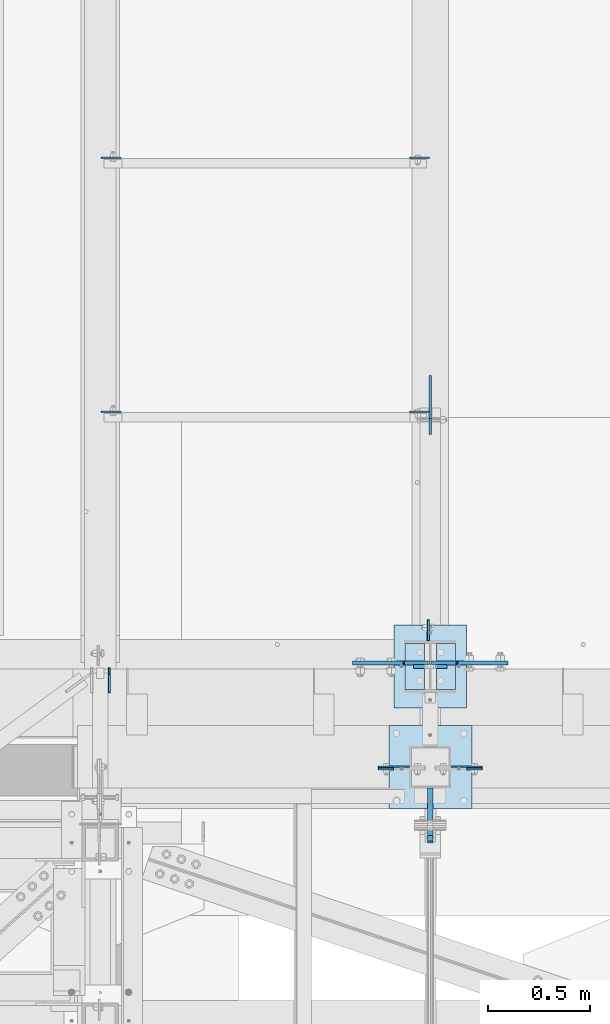
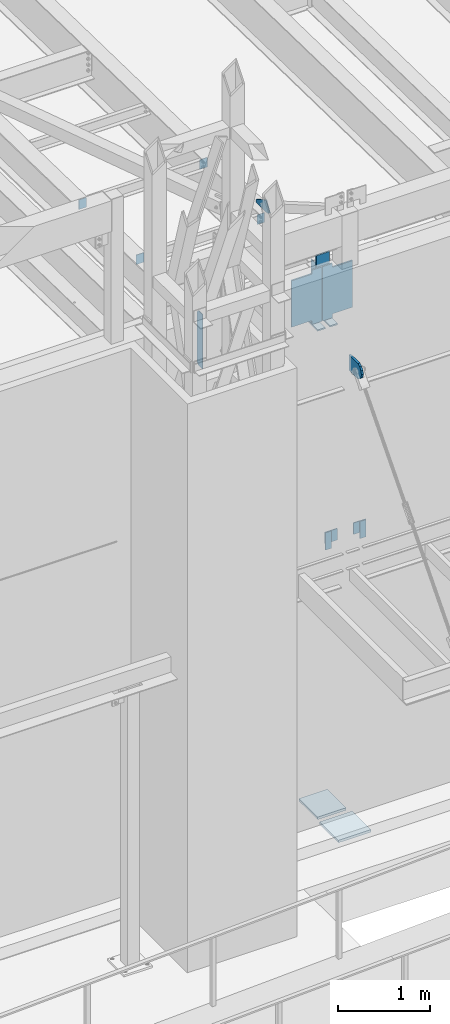
# One storey, part 1453 of 1763: 19 plates, 7 elements without a shape of their own.
"""IFC2X3 building model written with IfcOpenShell, lengths in millimetres."""

import ifcopenshell
import ifcopenshell.guid

model = None  # the IFC model being written
_history = None  # IfcOwnerHistory: only IFC2X3 demands one
_inside = {}  # id of a spatial element -> (the spatial element, [elements in it])
_under = {}  # id of a project, library or spatial element -> (it, [spatial elements below it])
_declared = {}  # id of a project -> (the project, [libraries it declares])
_typed = {}  # id of a type object -> (the type object, [elements of that type])
_made_of = {}  # id of a material, layer set ... -> (it, [elements and type objects made of it])


def new_model(schema):
    """Start an empty IFC model of exactly this schema.

    Asked for "IFC4X3", IfcOpenShell would pick the latest addendum, in which some entities
    have other attributes; the version numbers below select the first issue.
    IFC2X3 requires an IfcOwnerHistory on every rooted entity: one is made here for all.
    """
    global model, _history
    if schema == "IFC4X3":
        model = ifcopenshell.file(schema_version=(4, 3, 0, 0))
    else:
        model = ifcopenshell.file(schema=schema)
    _inside.clear()
    _under.clear()
    _declared.clear()
    _typed.clear()
    _made_of.clear()
    _history = None
    if model.schema == "IFC2X3":
        org = make("IfcOrganization", Name="unknown")
        user = make(
            "IfcPersonAndOrganization",
            ThePerson=make("IfcPerson", FamilyName="unknown"),
            TheOrganization=org,
        )
        app = make(
            "IfcApplication",
            ApplicationDeveloper=org,
            Version="unknown",
            ApplicationFullName="unknown",
            ApplicationIdentifier="unknown",
        )
        _history = make(
            "IfcOwnerHistory",
            OwningUser=user,
            OwningApplication=app,
            ChangeAction="ADDED",
            CreationDate=0,
        )
    return model


def make(cls, **values):
    """One entity of the class cls with the attributes given. An attribute that is None is left unset."""
    return model.create_entity(
        cls, **{name: value for name, value in values.items() if value is not None}
    )


def rooted(cls, **values):
    """An entity with a GlobalId (a new one), such as an element, a storey or a relation."""
    return make(cls, GlobalId=ifcopenshell.guid.new(), OwnerHistory=_history, **values)


def si_unit(unit_type, name, prefix=None):
    """IfcSIUnit, for example si_unit("LENGTHUNIT", "METRE", prefix="MILLI")."""
    return make("IfcSIUnit", UnitType=unit_type, Prefix=prefix, Name=name)


def assignment(units):
    """IfcUnitAssignment: the units of a project."""
    return None if units is None else make("IfcUnitAssignment", Units=units)


def point(xyz):
    """IfcCartesianPoint."""
    return None if xyz is None else make("IfcCartesianPoint", Coordinates=xyz)


def direction(xyz):
    """IfcDirection."""
    return None if xyz is None else make("IfcDirection", DirectionRatios=xyz)


def frame(location, z_axis=None, x_axis=None):
    """IfcAxis2Placement3D, a coordinate frame: its origin and axes. An axis left out is left unset."""
    return make(
        "IfcAxis2Placement3D",
        Location=point(location),
        Axis=direction(z_axis),
        RefDirection=direction(x_axis),
    )


def origin_with_axes():
    """The frame at (0, 0, 0) with the z axis (0, 0, 1) and the x axis (1, 0, 0) written out."""
    return frame((0.0, 0.0, 0.0), z_axis=(0.0, 0.0, 1.0), x_axis=(1.0, 0.0, 0.0))


def place(relative_to, where):
    """IfcLocalPlacement: puts the frame where relative to a parent placement (None: the world)."""
    return make(
        "IfcLocalPlacement", PlacementRelTo=relative_to, RelativePlacement=where
    )


def context(
    kind, dimensions, precision=None, world=None, true_north=None, identifier=None
):
    """IfcGeometricRepresentationContext, for example the 3D "Model" context."""
    return make(
        "IfcGeometricRepresentationContext",
        ContextIdentifier=identifier,
        ContextType=kind,
        CoordinateSpaceDimension=dimensions,
        Precision=precision,
        WorldCoordinateSystem=world,
        TrueNorth=true_north,
    )


def subcontext(parent, identifier, kind, view, scale=None):
    """IfcGeometricRepresentationSubContext, for example "Body" below "Model"."""
    return make(
        "IfcGeometricRepresentationSubContext",
        ContextIdentifier=identifier,
        ContextType=kind,
        ParentContext=parent,
        TargetScale=scale,
        TargetView=view,
    )


def project(units=None, contexts=None):
    """IfcProject with its units and contexts."""
    return rooted(
        "IfcProject",
        Name="project",
        RepresentationContexts=contexts,
        UnitsInContext=assignment(units),
    )


def spatial(cls, under=None, at=None, **own):
    """A site, building, storey or space (cls), placed at a placement, below another one or the project."""
    s = rooted(cls, ObjectPlacement=at, **own)
    if under is not None:
        _under.setdefault(under.id(), (under, []))[1].append(s)
    return s


def faces_of(points, faces, orient=None, outer=None):
    """IfcFace entities. A face is a list of loops; a loop is a list of indices into points, from 0.

    orient and outer hold one flag for each loop. By default every Orientation is true, the
    first loop of a face is its IfcFaceOuterBound and the others are IfcFaceBound.
    """
    made = []
    for i, loops in enumerate(faces):
        bounds = []
        for j, loop in enumerate(loops):
            is_outer = j == 0 if outer is None else outer[i][j]
            bounds.append(
                make(
                    "IfcFaceOuterBound" if is_outer else "IfcFaceBound",
                    Bound=make("IfcPolyLoop", Polygon=[points[k] for k in loop]),
                    Orientation=True if orient is None else orient[i][j],
                )
            )
        made.append(make("IfcFace", Bounds=bounds))
    return made


def faceted_brep(points, faces, orient=None, outer=None, voids=None):
    """IfcFacetedBrep: a solid bounded by flat faces; with voids (closed shells), ...WithVoids."""
    shared = [point(p) for p in points]
    hull = make("IfcClosedShell", CfsFaces=faces_of(shared, faces, orient, outer))
    if voids is None:
        return make("IfcFacetedBrep", Outer=hull)
    return make(
        "IfcFacetedBrepWithVoids",
        Outer=hull,
        Voids=[
            make(cls, CfsFaces=faces_of(shared, fs, o, b)) for cls, fs, o, b in voids
        ],
    )


def shape(context_of_items, identifier, shape_type, items):
    """IfcShapeRepresentation: the items that make up one representation, for example the "Body"."""
    return make(
        "IfcShapeRepresentation",
        ContextOfItems=context_of_items,
        RepresentationIdentifier=identifier,
        RepresentationType=shape_type,
        Items=items,
    )


def material(Name=None, Category=None):
    """IfcMaterial."""
    return make("IfcMaterial", Name=Name, Category=Category)


def made_of(thing, what):
    """Note that an element or type object is made of a material, layer set ...; save() writes the relation."""
    if what is not None:
        _made_of.setdefault(what.id(), (what, []))[1].append(thing)
    return thing


def type_object(cls, material=None, **own):
    """A type object (cls), such as IfcWallType, which elements share."""
    return made_of(rooted(cls, **own), material)


def element(
    cls,
    number,
    at=None,
    inside=None,
    cuts=None,
    type_object=None,
    material=None,
    context=None,
    identifier="Body",
    shape_type=None,
    held_by="IfcProductDefinitionShape",
    body=None,
    shapes=None,
    **own,
):
    """One element of the class cls, such as IfcWall. Its Tag is "e" and its number.

    at: its placement. inside: the storey or other place that contains it. cuts: it is an
    opening in that element (IfcRelVoidsElement). A single representation is given by context,
    identifier, shape_type and body (its items); several are given by shapes. held_by: the class
    of the entity that holds the representations. save() writes the other relations.
    """
    e = rooted(cls, Tag="e%d" % number, ObjectPlacement=at, **own)
    if body is not None:
        shapes = [shape(context, identifier, shape_type, body)]
    if shapes is not None:
        e.Representation = make(held_by, Representations=shapes)
    if inside is not None:
        _inside.setdefault(inside.id(), (inside, []))[1].append(e)
    if cuts is not None:
        rooted(
            "IfcRelVoidsElement", RelatingBuildingElement=cuts, RelatedOpeningElement=e
        )
    if type_object is not None:
        _typed.setdefault(type_object.id(), (type_object, []))[1].append(e)
    return made_of(e, material)


def aggregate(whole, parts):
    """IfcRelAggregates: a whole, such as a stair, and the parts it consists of."""
    return rooted("IfcRelAggregates", RelatingObject=whole, RelatedObjects=parts)


def save(model, path):
    """Write the relations noted so far, then the file.

    IfcRelAggregates (storeys below a building ...), IfcRelContainedInSpatialStructure (elements
    in a storey), IfcRelDefinesByType, IfcRelAssociatesMaterial and IfcRelDeclares: one each for
    every whole, place, type object, material and project.
    """
    for whole, parts in _under.values():
        aggregate(whole, parts)
    for where, things in _inside.values():
        rooted(
            "IfcRelContainedInSpatialStructure",
            RelatedElements=things,
            RelatingStructure=where,
        )
    for kind, things in _typed.values():
        rooted("IfcRelDefinesByType", RelatedObjects=things, RelatingType=kind)
    for what, things in _made_of.values():
        rooted("IfcRelAssociatesMaterial", RelatedObjects=things, RelatingMaterial=what)
    for by, libraries in _declared.values():
        rooted("IfcRelDeclares", RelatingContext=by, RelatedDefinitions=libraries)
    model.write(path)


model = new_model("IFC2X3")

# Units and contexts
model_context = context("Model", 3, precision=1e-05, world=origin_with_axes())
body_context = subcontext(model_context, "Body", "Model", "MODEL_VIEW")
ifc_project = project(units=[si_unit("LENGTHUNIT", "METRE", prefix="MILLI"), si_unit("AREAUNIT", "SQUARE_METRE"), si_unit("VOLUMEUNIT", "CUBIC_METRE"), si_unit("MASSUNIT", "GRAM", prefix="KILO"), si_unit("TIMEUNIT", "SECOND"), si_unit("PLANEANGLEUNIT", "RADIAN"), si_unit("SOLIDANGLEUNIT", "STERADIAN"), si_unit("THERMODYNAMICTEMPERATUREUNIT", "DEGREE_CELSIUS"), si_unit("LUMINOUSINTENSITYUNIT", "LUMEN")], contexts=[model_context])

# Site, building, storey
site_placement = place(None, origin_with_axes())
site = spatial("IfcSite", under=ifc_project, at=site_placement, CompositionType="ELEMENT")
building_placement = place(site_placement, origin_with_axes())
building = spatial("IfcBuilding", under=site, at=building_placement, Name="Undefined", CompositionType="ELEMENT")
storey_placement = place(building_placement, origin_with_axes())
storey = spatial("IfcBuildingStorey", under=building, at=storey_placement, Name="Undefined", CompositionType="ELEMENT", Elevation=0.0)

# Assembly, plate
assembly_1_placement = place(storey_placement, origin_with_axes())
assembly_1 = element("IfcElementAssembly", 1, at=assembly_1_placement, inside=storey, Name="BEAM", AssemblyPlace="NOTDEFINED", PredefinedType="RIGID_FRAME")
ifc_material_1 = material(Name="STEEL/A36")
plate_type_1 = type_object("IfcPlateType", PredefinedType="NOTDEFINED")
plate_1_placement = place(assembly_1_placement, frame((-61772.2270217928, -14217.6526375877, 8839.2), z_axis=(0.0, 0.0, 1.0), x_axis=(-1.0, 0.0, 0.0)))
plate_1 = element("IfcPlate", 2, at=plate_1_placement, type_object=plate_type_1, material=ifc_material_1, Name="PLATE", context=body_context, shape_type="Brep", body=[
    faceted_brep([(0.0, -4.76249999999982, 0.0), (-2.83762346953154e-10, -4.7624999996915, 228.600006103516), (-2.83762346953154e-10, 4.76250000028813, 228.600006103517), (0.0, 4.76249999999982, 0.0), (76.1999969480166, -4.76249999961874, 228.600006103516), (76.1999969480166, 4.76250000036089, 228.600006103517), (76.1999969482931, -4.76249999991705, 0.0), (76.1999969482931, 4.76250000006257, 1.81898940354586e-12)], [[[0, 1, 2, 3]], [[1, 4, 5, 2]], [[4, 6, 7, 5]], [[6, 0, 3, 7]], [[5, 7, 3, 2]], [[6, 4, 1, 0]]]),
])
aggregate(assembly_1, [plate_1])

assembly_2_placement = place(storey_placement, origin_with_axes())
assembly_2 = element("IfcElementAssembly", 3, at=assembly_2_placement, inside=storey, Name="BEAM", AssemblyPlace="NOTDEFINED", PredefinedType="RIGID_FRAME")
plate_2_placement = place(assembly_2_placement, frame((-61416.6269978255, -14217.6526358086, 8839.2), z_axis=(0.0, 0.0, 1.0), x_axis=(1.0, 0.0, 0.0)))
plate_2 = element("IfcPlate", 4, at=plate_2_placement, type_object=plate_type_1, material=ifc_material_1, Name="PLATE", context=body_context, shape_type="Brep", body=[
    faceted_brep([(0.0, -4.76249999999982, 0.0), (-2.83762346953154e-10, -4.7624999996915, 228.600006103516), (-2.83762346953154e-10, 4.76250000028813, 228.600006103517), (0.0, 4.76249999999982, 0.0), (76.1999969480166, -4.76249999961874, 228.600006103516), (76.1999969480166, 4.76250000036089, 228.600006103517), (76.1999969482931, -4.76249999991705, 0.0), (76.1999969482931, 4.76250000006257, 1.81898940354586e-12)], [[[0, 1, 2, 3]], [[1, 4, 5, 2]], [[4, 6, 7, 5]], [[6, 0, 3, 7]], [[5, 7, 3, 2]], [[6, 4, 1, 0]]]),
])
aggregate(assembly_2, [plate_2])

assembly_3_placement = place(storey_placement, origin_with_axes())
assembly_3 = element("IfcElementAssembly", 5, at=assembly_3_placement, inside=storey, Name="BEAM", AssemblyPlace="NOTDEFINED", PredefinedType="RIGID_FRAME")
plate_type_2 = type_object("IfcPlateType", PredefinedType="NOTDEFINED")
plate_3_placement = place(assembly_3_placement, frame((-63166.0535957005, -13843.7935686174, 11466.5125), z_axis=(0.0, 0.0, 1.0), x_axis=(0.0, 1.0, 0.0)))
plate_3 = element("IfcPlate", 6, at=plate_3_placement, type_object=plate_type_2, material=ifc_material_1, Name="PLATE", context=body_context, shape_type="Brep", body=[
    faceted_brep([(0.0, -4.76249999999982, 0.0), (0.0, -4.76249999999709, 717.549987792969), (0.0, 4.76249999999709, 717.549987792969), (0.0, 4.76249999999982, 0.0), (88.9000015258789, -4.76249999999709, 717.549987792969), (88.9000015258789, 4.76249999999709, 717.549987792969), (120.650001525879, -4.76249999999709, 685.799987792969), (120.650001525879, 4.76249999999709, 685.799987792969), (120.650001525879, -4.76249999999709, 31.75), (120.650001525879, 4.76249999999709, 31.75), (88.9000015258789, -4.76249999999709, 0.0), (88.9000015258789, 4.76249999999709, 0.0)], [[[0, 1, 2, 3]], [[1, 4, 5, 2]], [[4, 6, 7, 5]], [[6, 8, 9, 7]], [[8, 10, 11, 9]], [[10, 0, 3, 11]], [[5, 7, 9, 11, 3, 2]], [[10, 8, 6, 4, 1, 0]]]),
])
aggregate(assembly_3, [plate_3])

# Assembly, plates
assembly_4_placement = place(storey_placement, origin_with_axes())
assembly_4 = element("IfcElementAssembly", 7, at=assembly_4_placement, inside=storey, Name="COLUMN", AssemblyPlace="NOTDEFINED", PredefinedType="RIGID_FRAME")
plate_type_3 = type_object("IfcPlateType", PredefinedType="NOTDEFINED")
plate_4_placement = place(assembly_4_placement, frame((-61848.4270187887, -14208.1276390874, 9067.80000610352), z_axis=(0.0, 0.0, -1.0), x_axis=(1.0, 0.0, 0.0)))
plate_4 = element("IfcPlate", 8, at=plate_4_placement, type_object=plate_type_3, material=ifc_material_1, Name="PLATE", context=body_context, shape_type="Brep", body=[
    faceted_brep([(0.0, -4.76249999999982, 0.0), (-3.05175672110636e-06, -4.7625000002663, 152.399993896484), (-3.05175490211695e-06, 4.76249999972788, 152.399993896484), (0.0, 4.76249999999982, 0.0), (152.400009155272, -4.76249999975698, 152.399993896484), (152.400009155273, 4.76250000024447, 152.399993896484), (152.400009155272, -4.76249999948777, 5.45696821063757e-12), (152.400009155273, 4.76250000051368, 3.63797880709171e-12)], [[[0, 1, 2, 3]], [[1, 4, 5, 2]], [[4, 6, 7, 5]], [[6, 0, 3, 7]], [[5, 7, 3, 2]], [[6, 4, 1, 0]]]),
])
plate_5_placement = place(assembly_4_placement, frame((-61340.4270009248, -14208.1276365458, 9067.80000610352), z_axis=(0.0, 0.0, -1.0), x_axis=(-1.0, 0.0, 0.0)))
plate_5 = element("IfcPlate", 9, at=plate_5_placement, type_object=plate_type_3, material=ifc_material_1, Name="PLATE", context=body_context, shape_type="Brep", body=[
    faceted_brep([(0.0, -4.76249999999982, 0.0), (-3.05175672110636e-06, -4.7625000002663, 152.399993896484), (-3.05175490211695e-06, 4.76249999972788, 152.399993896484), (0.0, 4.76249999999982, 0.0), (152.400009155272, -4.76249999975698, 152.399993896484), (152.400009155273, 4.76250000024447, 152.399993896484), (152.400009155272, -4.76249999948777, 5.45696821063757e-12), (152.400009155273, 4.76250000051368, 3.63797880709171e-12)], [[[0, 1, 2, 3]], [[1, 4, 5, 2]], [[4, 6, 7, 5]], [[6, 0, 3, 7]], [[5, 7, 3, 2]], [[6, 4, 1, 0]]]),
])

assembly_5_placement = place(storey_placement, origin_with_axes())
assembly_5 = element("IfcElementAssembly", 10, at=assembly_5_placement, inside=storey, Name="BEAM", AssemblyPlace="NOTDEFINED", PredefinedType="RIGID_FRAME")
plate_type_4 = type_object("IfcPlateType", PredefinedType="NOTDEFINED")
plate_6_placement = place(assembly_5_placement, frame((-63205.5045725783, -12468.6187192313, 12153.2886368763), z_axis=(1.0, 0.0, 0.0), x_axis=(0.0, 0.0, -1.0)))
plate_6 = element("IfcPlate", 11, at=plate_6_placement, type_object=plate_type_4, material=ifc_material_1, Name="PLATE", context=body_context, shape_type="Brep", body=[
    faceted_brep([(1.81898940354586e-12, -3.17500000000291, 0.0), (0.0, -3.17499999999927, 95.25), (0.0, 3.17499999999927, 95.25), (-1.81898940354586e-12, 3.17499999997381, 0.0), (127.0, -3.17499999999927, 95.25), (127.0, 3.17499999999927, 95.25), (127.0, -3.17499999999927, 0.0), (127.0, 3.17499999999927, 0.0)], [[[0, 1, 2, 3]], [[1, 4, 5, 2]], [[4, 6, 7, 5]], [[6, 0, 3, 7]], [[5, 7, 3, 2]], [[6, 4, 1, 0]]]),
])
plate_7_placement = place(assembly_5_placement, frame((-63205.5045725783, -11224.4126198456, 12127.2773623981), z_axis=(1.0, 0.0, 0.0), x_axis=(0.0, 0.0, -1.0)))
plate_7 = element("IfcPlate", 12, at=plate_7_placement, type_object=plate_type_4, material=ifc_material_1, Name="PLATE", context=body_context, shape_type="Brep", body=[
    faceted_brep([(1.81898940354586e-12, -3.17500000000291, 0.0), (0.0, -3.17499999999927, 95.25), (0.0, 3.17499999999927, 95.25), (-1.81898940354586e-12, 3.17499999997381, 0.0), (127.0, -3.17499999999927, 95.25), (127.0, 3.17499999999927, 95.25), (127.0, -3.17499999999927, 0.0), (127.0, 3.17499999999927, 0.0)], [[[0, 1, 2, 3]], [[1, 4, 5, 2]], [[4, 6, 7, 5]], [[6, 0, 3, 7]], [[5, 7, 3, 2]], [[6, 4, 1, 0]]]),
])
aggregate(assembly_5, [plate_6, plate_7])

assembly_6_placement = place(storey_placement, origin_with_axes())
assembly_6 = element("IfcElementAssembly", 13, at=assembly_6_placement, inside=storey, Name="BEAM", AssemblyPlace="NOTDEFINED", PredefinedType="RIGID_FRAME")
plate_8_placement = place(assembly_6_placement, frame((-61599.1997736983, -12468.6187192313, 12153.2886368765), z_axis=(-1.0, 0.0, 0.0), x_axis=(0.0, 0.0, -1.0)))
plate_8 = element("IfcPlate", 14, at=plate_8_placement, type_object=plate_type_4, material=ifc_material_1, Name="PLATE", context=body_context, shape_type="Brep", body=[
    faceted_brep([(1.81898940354586e-12, -3.17500000000291, 0.0), (0.0, -3.17499999999927, 95.25), (0.0, 3.17499999999927, 95.25), (-1.81898940354586e-12, 3.17499999997381, 0.0), (127.0, -3.17499999999927, 95.25), (127.0, 3.17499999999927, 95.25), (127.0, -3.17499999999927, 0.0), (127.0, 3.17499999999927, 0.0)], [[[0, 1, 2, 3]], [[1, 4, 5, 2]], [[4, 6, 7, 5]], [[6, 0, 3, 7]], [[5, 7, 3, 2]], [[6, 4, 1, 0]]]),
])
plate_9_placement = place(assembly_6_placement, frame((-61599.1997736983, -11224.4126198457, 12127.2773623985), z_axis=(-1.0, 0.0, 0.0), x_axis=(0.0, 0.0, -1.0)))
plate_9 = element("IfcPlate", 15, at=plate_9_placement, type_object=plate_type_4, material=ifc_material_1, Name="PLATE", context=body_context, shape_type="Brep", body=[
    faceted_brep([(1.81898940354586e-12, -3.17500000000291, 0.0), (0.0, -3.17499999999927, 95.25), (0.0, 3.17499999999927, 95.25), (-1.81898940354586e-12, 3.17499999997381, 0.0), (127.0, -3.17499999999927, 95.25), (127.0, 3.17499999999927, 95.25), (127.0, -3.17499999999927, 0.0), (127.0, 3.17499999999927, 0.0)], [[[0, 1, 2, 3]], [[1, 4, 5, 2]], [[4, 6, 7, 5]], [[6, 0, 3, 7]], [[5, 7, 3, 2]], [[6, 4, 1, 0]]]),
])

# Plate
plate_type_5 = type_object("IfcPlateType", PredefinedType="NOTDEFINED")
plate_10_placement = place(assembly_4_placement, frame((-61594.4270083209, -14503.4026217954, 11188.7000003081), z_axis=(0.0, 0.0, 1.0), x_axis=(0.0, 1.0, 0.0)))
plate_10 = element("IfcPlate", 16, at=plate_10_placement, type_object=plate_type_5, material=ifc_material_1, Name="PLATE", context=body_context, shape_type="Brep", body=[
    faceted_brep([(0.0, -12.6999999999971, -1.81898940354586e-12), (-39.5764506670585, -12.6999999999971, 21.5331529121049), (-39.5764506670585, 12.6999999999971, 21.5331529121049), (0.0, 12.6999999999971, -1.81898940354586e-12), (-66.6095773920388, -12.6999999999971, 57.5773227764421), (-66.6095773920388, 12.6999999999971, 57.5773227764421), (-76.199996948335, -12.6999999999971, 101.599998461508), (-76.199996948335, 12.6999999999971, 101.599998461508), (-66.6095774066125, -12.6999999999971, 145.622674149748), (-66.6095774066125, 12.6999999999971, 145.622674149748), (-39.5764506935648, -12.6999999999971, 181.666844023039), (-39.5764506935648, 12.6999999999971, 181.666844023039), (-3.36349330609664e-08, -12.6999999999971, 203.199996948242), (-3.36349330609664e-08, 12.6999999999971, 203.199996948242), (193.675003051578, -12.6999999999971, 203.199996948413), (193.675003051578, 12.6999999999971, 203.199996948413), (193.675003051758, -12.6999999999971, 3.09228198602796e-10), (193.675003051758, 12.6999999999971, 3.09228198602796e-10)], [[[0, 1, 2, 3]], [[1, 4, 5, 2]], [[4, 6, 7, 5]], [[6, 8, 9, 7]], [[8, 10, 11, 9]], [[10, 12, 13, 11]], [[12, 14, 15, 13]], [[14, 16, 17, 15]], [[16, 0, 3, 17]], [[5, 7, 9, 11, 13, 15, 17, 3, 2]], [[16, 14, 12, 10, 8, 6, 4, 1, 0]]]),
])

# Assembly, plate
assembly_7_placement = place(storey_placement, origin_with_axes())
assembly_7 = element("IfcElementAssembly", 17, at=assembly_7_placement, inside=storey, Name="COLUMN", AssemblyPlace="NOTDEFINED", PredefinedType="RIGID_FRAME")
ifc_material_2 = material(Name="STEEL/A572-50")
plate_type_6 = type_object("IfcPlateType", PredefinedType="NOTDEFINED")
plate_11_placement = place(assembly_7_placement, frame((-61511.8872721725, -13715.9998186171, 12369.7999938965), z_axis=(0.0, 0.0, -1.0), x_axis=(-1.0, 0.0, 0.0)))
plate_11 = element("IfcPlate", 18, at=plate_11_placement, type_object=plate_type_6, material=ifc_material_2, Name="PLATE", context=body_context, shape_type="Brep", body=[
    faceted_brep([(7.27595761418343e-12, 9.52500000000146, 155.574990844727), (-1.45519152283669e-11, 7.27595761418343e-12, 165.099990844727), (165.099990844727, 0.0, 165.099990844727), (165.099990844727, 9.52500000000146, 155.574990844727), (-3.63797880709171e-11, -9.5249999999869, 155.574990844727), (165.099990844727, -9.52500000000146, 155.574990844727), (0.0, 9.52500000000146, 0.0), (0.0, -9.52500000000146, 0.0), (165.099990844727, -9.52500000000146, 0.0), (165.099990844727, 9.52500000000146, 0.0)], [[[0, 1, 2, 3]], [[1, 4, 5, 2]], [[6, 7, 4, 1, 0]], [[5, 8, 9, 3, 2]], [[8, 7, 6, 9]], [[9, 6, 0, 3]], [[7, 8, 5, 4]]]),
])

# Plate
plate_type_7 = type_object("IfcPlateType", PredefinedType="NOTDEFINED")
plate_12_placement = place(assembly_6_placement, frame((-61594.4377751502, -12289.5645131378, 12174.8790507221), z_axis=(0.0, -1.0, 0.0), x_axis=(0.0, 0.0, 1.0)))
plate_12 = element("IfcPlate", 19, at=plate_12_placement, type_object=plate_type_7, material=ifc_material_1, Name="PLATE", context=body_context, shape_type="Brep", body=[
    faceted_brep([(0.0, -6.34999999999491, 1.45519152283669e-11), (3.45059657096863, -6.34999999999854, 165.063949584961), (3.45059657096863, 6.34999999999854, 165.063949584961), (0.0, 6.34999999999491, -2.91038304567337e-11), (5.01950931549072, -6.34999999999854, 240.10026550293), (5.01950931549072, 6.34999999999854, 240.10026550293), (33.3607749938965, -6.34999999999854, 288.962707519531), (33.3607749938965, 6.34999999999854, 288.962707519531), (165.188125610352, -6.34999999999854, 212.500045776367), (165.188125610352, 6.34999999999854, 212.500045776367), (41.9335784912109, -6.34999999999854, 0.0), (41.9335784912109, 6.34999999999854, 0.0)], [[[0, 1, 2, 3]], [[1, 4, 5, 2]], [[4, 6, 7, 5]], [[6, 8, 9, 7]], [[8, 10, 11, 9]], [[10, 0, 3, 11]], [[5, 7, 9, 11, 3, 2]], [[10, 8, 6, 4, 1, 0]]]),
])

aggregate(assembly_6, [plate_8, plate_9, plate_12])

plate_type_8 = type_object("IfcPlateType", PredefinedType="NOTDEFINED")
plate_13_placement = place(assembly_7_placement, frame((-61603.9622736983, -13588.9999999999, 12162.6007753759), z_axis=(0.0, 1.0, 0.0), x_axis=(0.0, 0.0, -1.0)))
plate_13 = element("IfcPlate", 20, at=plate_13_placement, type_object=plate_type_8, material=ifc_material_1, Name="PLATE", context=body_context, shape_type="Brep", body=[
    faceted_brep([(0.0, -4.76249999999982, 0.0), (1.45519152283669e-11, -4.76250000000448, 101.60001373291), (0.0, 4.76250000000243, 101.60001373291), (0.0, 4.76249999999982, 0.0), (533.400024414062, -4.76249999999709, 101.599998474121), (533.400024414062, 4.76249999999709, 101.599998474121), (533.400024414062, -4.76250000000073, 0.0), (533.400024414062, 4.76250000000073, 0.0)], [[[0, 1, 2, 3]], [[1, 4, 5, 2]], [[4, 6, 7, 5]], [[6, 0, 3, 7]], [[5, 7, 3, 2]], [[6, 4, 1, 0]]]),
])

plate_type_9 = type_object("IfcPlateType", PredefinedType="NOTDEFINED")
plate_14_placement = place(assembly_7_placement, frame((-61598.4060236983, -13699.3310686171, 12184.0625), z_axis=(-1.0, 0.0, 0.0), x_axis=(0.0, 0.0, -1.0)))
plate_14 = element("IfcPlate", 21, at=plate_14_placement, type_object=plate_type_9, material=ifc_material_2, Name="PLATE", context=body_context, shape_type="Brep", body=[
    faceted_brep([(38.0999994277954, -9.52499999999964, 123.03125), (38.0999994277954, 9.52499999999964, 123.03125), (0.0, 9.52499999999964, 123.03125), (0.0, -9.52499999999964, 123.03125), (42.9600789458418, -9.52499999999964, 123.997979922591), (42.9600789458418, 9.52499999999964, 123.997979922591), (47.0802554139955, -9.52499999999964, 126.750993823065), (47.0802554139955, 9.52499999999964, 126.750993823065), (49.833269314473, -9.52499999999964, 130.871170291219), (49.833269314473, 9.52499999999964, 130.871170291219), (50.7999992370605, -9.52499999999964, 135.731249809265), (50.7999992370605, 9.52499999999964, 135.731249809265), (50.7999992370605, -9.52499999999964, 377.03125), (50.7999992370605, 9.52499999999964, 377.03125), (717.549987792969, -9.52500000000146, 0.0), (0.0, -9.52500000000146, 0.0), (0.0, 9.52500000000146, 0.0), (717.549987792969, 9.52500000000146, 0.0), (717.549987792969, 9.52499999999964, 123.03125), (717.549987792969, -9.52499999999964, 123.03125), (679.449988365173, 9.52499999999964, 123.03125), (679.449988365173, -9.52499999999964, 123.03125), (674.589908847127, 9.52499999999964, 123.997979922591), (674.589908847127, -9.52499999999964, 123.997979922591), (670.469732378973, 9.52499999999964, 126.750993823065), (670.469732378973, -9.52499999999964, 126.750993823065), (667.716718478496, 9.52499999999964, 130.871170291219), (667.716718478496, -9.52499999999964, 130.871170291219), (666.749988555908, 9.52499999999964, 135.731249809265), (666.749988555908, -9.52499999999964, 135.731249809265), (666.749988555908, -9.52499999999964, 377.03125), (666.749988555908, 9.52499999999964, 377.03125)], [[[0, 1, 2, 3]], [[4, 5, 1, 0]], [[6, 7, 5, 4]], [[8, 9, 7, 6]], [[10, 11, 9, 8]], [[12, 13, 11, 10]], [[14, 15, 16, 17]], [[14, 17, 18, 19]], [[19, 18, 20, 21]], [[21, 20, 22, 23]], [[23, 22, 24, 25]], [[25, 24, 26, 27]], [[27, 26, 28, 29]], [[30, 29, 28, 31]], [[8, 6, 4, 0, 3, 15, 14, 19, 21, 23, 25, 27, 29, 30, 12, 10]], [[16, 15, 3, 2]], [[31, 28, 26, 24, 22, 20, 18, 17, 16, 2, 1, 5, 7, 9, 11, 13]], [[30, 31, 13, 12]]]),
])

plate_15_placement = place(assembly_7_placement, frame((-61590.4685236983, -13699.3310686171, 12184.0625), z_axis=(1.0, 0.0, 0.0), x_axis=(0.0, 0.0, -1.0)))
plate_15 = element("IfcPlate", 22, at=plate_15_placement, type_object=plate_type_9, material=ifc_material_2, Name="PLATE", context=body_context, shape_type="Brep", body=[
    faceted_brep([(38.0999994277954, -9.52499999999964, 123.03125), (38.0999994277954, 9.52499999999964, 123.03125), (0.0, 9.52499999999964, 123.03125), (0.0, -9.52499999999964, 123.03125), (42.9600789458418, -9.52499999999964, 123.997979922591), (42.9600789458418, 9.52499999999964, 123.997979922591), (47.0802554139955, -9.52499999999964, 126.750993823065), (47.0802554139955, 9.52499999999964, 126.750993823065), (49.833269314473, -9.52499999999964, 130.871170291219), (49.833269314473, 9.52499999999964, 130.871170291219), (50.7999992370605, -9.52499999999964, 135.731249809265), (50.7999992370605, 9.52499999999964, 135.731249809265), (50.7999992370605, -9.52499999999964, 377.03125), (50.7999992370605, 9.52499999999964, 377.03125), (717.549987792969, -9.52500000000146, 0.0), (0.0, -9.52500000000146, 0.0), (0.0, 9.52500000000146, 0.0), (717.549987792969, 9.52500000000146, 0.0), (717.549987792969, 9.52499999999964, 123.03125), (717.549987792969, -9.52499999999964, 123.03125), (679.449988365173, 9.52499999999964, 123.03125), (679.449988365173, -9.52499999999964, 123.03125), (674.589908847127, 9.52499999999964, 123.997979922591), (674.589908847127, -9.52499999999964, 123.997979922591), (670.469732378973, 9.52499999999964, 126.750993823065), (670.469732378973, -9.52499999999964, 126.750993823065), (667.716718478496, 9.52499999999964, 130.871170291219), (667.716718478496, -9.52499999999964, 130.871170291219), (666.749988555908, 9.52499999999964, 135.731249809265), (666.749988555908, -9.52499999999964, 135.731249809265), (666.749988555908, -9.52499999999964, 377.03125), (666.749988555908, 9.52499999999964, 377.03125)], [[[0, 1, 2, 3]], [[4, 5, 1, 0]], [[6, 7, 5, 4]], [[8, 9, 7, 6]], [[10, 11, 9, 8]], [[12, 13, 11, 10]], [[14, 15, 16, 17]], [[14, 17, 18, 19]], [[19, 18, 20, 21]], [[21, 20, 22, 23]], [[23, 22, 24, 25]], [[25, 24, 26, 27]], [[27, 26, 28, 29]], [[30, 29, 28, 31]], [[8, 6, 4, 0, 3, 15, 14, 19, 21, 23, 25, 27, 29, 30, 12, 10]], [[16, 15, 3, 2]], [[31, 28, 26, 24, 22, 20, 18, 17, 16, 2, 1, 5, 7, 9, 11, 13]], [[30, 31, 13, 12]]]),
])

plate_type_10 = type_object("IfcPlateType", PredefinedType="NOTDEFINED")
plate_16_placement = place(assembly_7_placement, frame((-61772.2372736984, -13512.8, 5083.175), z_axis=(1.0, 0.0, 0.0), x_axis=(0.0, -1.0, 0.0)))
plate_16 = element("IfcPlate", 23, at=plate_16_placement, type_object=plate_type_10, material=ifc_material_1, Name="PLATE", context=body_context, shape_type="Brep", body=[
    faceted_brep([(0.0, -15.875, 0.0), (0.0, -15.875, 355.600006103516), (0.0, 15.875, 355.600006103516), (0.0, 15.875, 0.0), (406.399993896484, -15.875, 355.600006103516), (406.399993896484, 15.875, 355.600006103516), (406.399993896484, -15.875, 0.0), (406.399993896484, 15.875, 0.0)], [[[0, 1, 2, 3]], [[1, 4, 5, 2]], [[4, 6, 7, 5]], [[6, 0, 3, 7]], [[5, 7, 3, 2]], [[6, 4, 1, 0]]]),
])

plate_type_11 = type_object("IfcPlateType", PredefinedType="NOTDEFINED")
plate_17_placement = place(assembly_7_placement, frame((-61719.0560236984, -13603.2875, 11456.987512207), z_axis=(0.0, -1.0, 0.0), x_axis=(1.0, 0.0, 0.0)))
plate_17 = element("IfcPlate", 24, at=plate_17_placement, type_object=plate_type_11, material=ifc_material_1, Name="PLATE", context=body_context, shape_type="Brep", body=[
    faceted_brep([(0.0, -9.52500000000146, 0.0), (0.0, -9.52499999999964, 225.425003051758), (0.0, 9.52499999999964, 225.425003051758), (0.0, 9.52500000000146, 0.0), (95.25, -9.52499999999964, 225.425003051758), (95.25, 9.52499999999964, 225.425003051758), (95.2499921933502, -9.52499999999964, 0.0), (95.2499921933502, 9.52499999999964, 0.0)], [[[0, 1, 2, 3]], [[1, 4, 5, 2]], [[4, 6, 7, 5]], [[0, 3, 7, 6]], [[5, 7, 3, 2]], [[6, 4, 1, 0]]]),
])

plate_18_placement = place(assembly_7_placement, frame((-61469.8185236983, -13828.7125, 11456.987512207), z_axis=(0.0, 1.0, 0.0), x_axis=(-1.0, 0.0, 0.0)))
plate_18 = element("IfcPlate", 25, at=plate_18_placement, type_object=plate_type_11, material=ifc_material_1, Name="PLATE", context=body_context, shape_type="Brep", body=[
    faceted_brep([(0.0, -9.52500000000146, 0.0), (0.0, -9.52499999999964, 225.425003051758), (0.0, 9.52499999999964, 225.425003051758), (0.0, 9.52500000000146, 0.0), (95.25, -9.52499999999964, 225.425003051758), (95.25, 9.52499999999964, 225.425003051758), (95.2499921933502, -9.52499999999964, 0.0), (95.2499921933502, 9.52499999999964, 0.0)], [[[0, 1, 2, 3]], [[1, 4, 5, 2]], [[4, 6, 7, 5]], [[0, 3, 7, 6]], [[5, 7, 3, 2]], [[6, 4, 1, 0]]]),
])

aggregate(assembly_7, [plate_11, plate_13, plate_17, plate_14, plate_18, plate_15, plate_16])

plate_type_12 = type_object("IfcPlateType", PredefinedType="NOTDEFINED")
plate_19_placement = place(assembly_4_placement, frame((-61797.6270098567, -14004.9276214906, 5083.175), z_axis=(1.0, 0.0, 0.0), x_axis=(0.0, -1.0, 0.0)))
plate_19 = element("IfcPlate", 26, at=plate_19_placement, type_object=plate_type_12, material=ifc_material_1, Name="PLATE", context=body_context, shape_type="Brep", body=[
    faceted_brep([(0.0, -15.875, 0.0), (0.0, -15.875, 406.399993896484), (0.0, 15.875, 406.399993896484), (0.0, 15.875, 0.0), (406.399993896484, -15.875, 406.399993896484), (406.399993896484, 15.875, 406.399993896484), (406.399993896484, -15.875, 0.0), (406.399993896484, 15.875, 0.0)], [[[0, 1, 2, 3]], [[1, 4, 5, 2]], [[4, 6, 7, 5]], [[6, 0, 3, 7]], [[5, 7, 3, 2]], [[6, 4, 1, 0]]]),
])

aggregate(assembly_4, [plate_4, plate_5, plate_10, plate_19])

save(model, "model.ifc")
